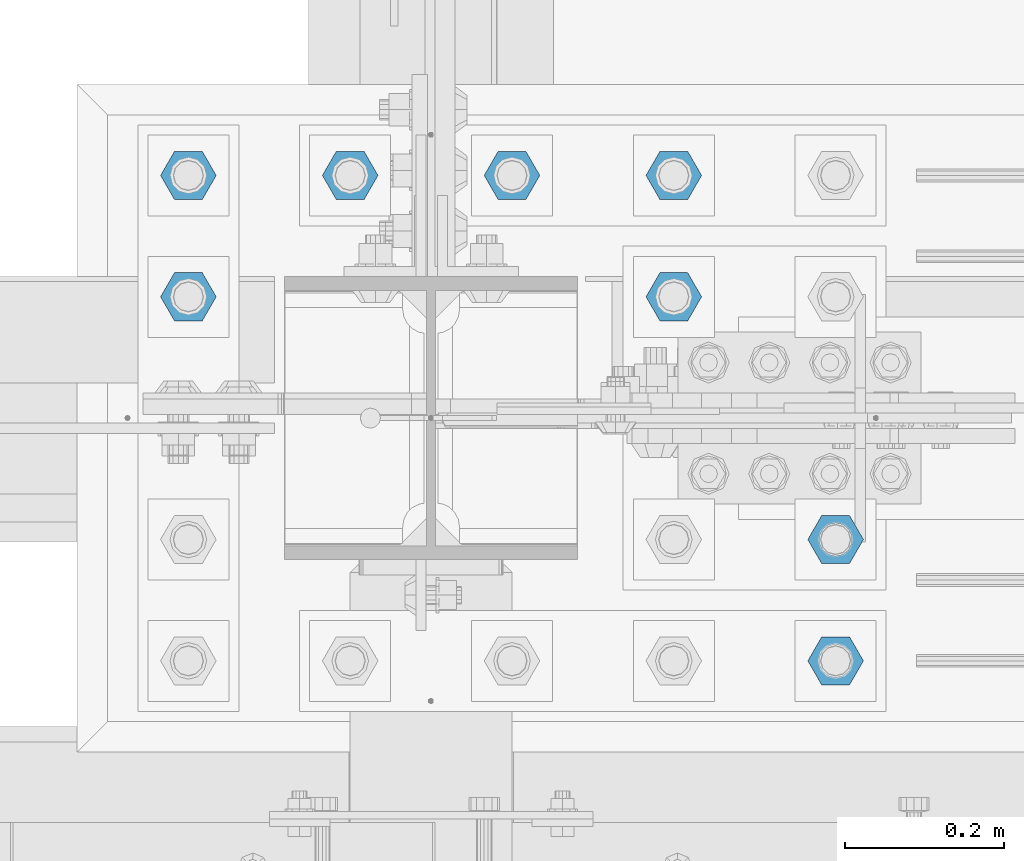
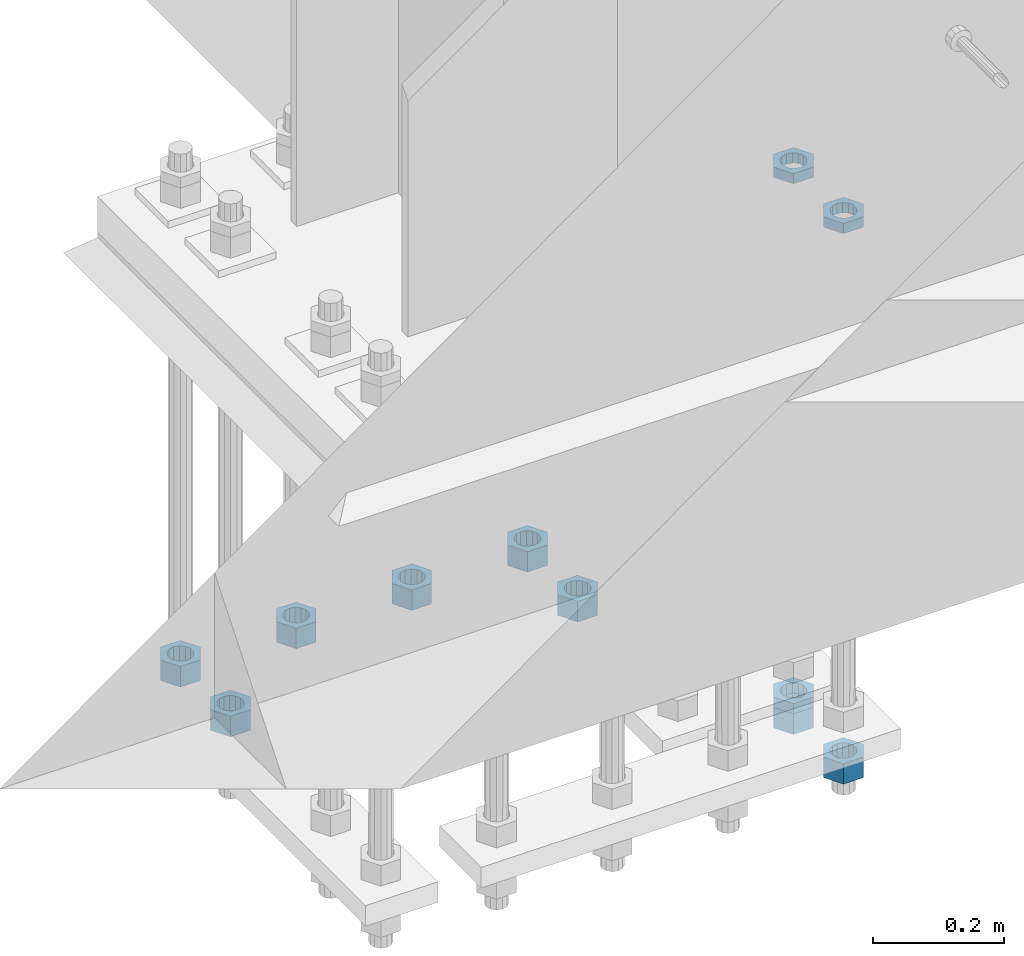
# One storey, part 2792 of 3843: 11 beams, 1 element without a shape of its own.
"""IFC2X3 building model written with IfcOpenShell, lengths in millimetres."""

from ifc_helpers import new_model, si_unit, frame, origin_with_axes, place, context, subcontext, project, spatial, faceted_brep, material, type_object, element, aggregate, save


model = new_model("IFC2X3")

# Units and contexts
model_context = context("Model", 3, precision=1e-05, world=origin_with_axes())
body_context = subcontext(model_context, "Body", "Model", "MODEL_VIEW")
ifc_project = project(units=[si_unit("LENGTHUNIT", "METRE", prefix="MILLI"), si_unit("AREAUNIT", "SQUARE_METRE"), si_unit("VOLUMEUNIT", "CUBIC_METRE"), si_unit("MASSUNIT", "GRAM", prefix="KILO"), si_unit("TIMEUNIT", "SECOND"), si_unit("PLANEANGLEUNIT", "RADIAN"), si_unit("SOLIDANGLEUNIT", "STERADIAN"), si_unit("THERMODYNAMICTEMPERATUREUNIT", "DEGREE_CELSIUS"), si_unit("LUMINOUSINTENSITYUNIT", "LUMEN")], contexts=[model_context])

# Site, building, storey
site_placement = place(None, origin_with_axes())
site = spatial("IfcSite", under=ifc_project, at=site_placement, CompositionType="ELEMENT")
building_placement = place(site_placement, origin_with_axes())
building = spatial("IfcBuilding", under=site, at=building_placement, Name="Undefined", CompositionType="ELEMENT")
storey_placement = place(building_placement, origin_with_axes())
storey = spatial("IfcBuildingStorey", under=building, at=storey_placement, Name="Undefined", CompositionType="ELEMENT", Elevation=0.0)

# Assembly, beams
assembly_placement = place(storey_placement, origin_with_axes())
assembly = element("IfcElementAssembly", 1, at=assembly_placement, inside=storey, Name="TEMPLATE", AssemblyPlace="NOTDEFINED", PredefinedType="RIGID_FRAME")
ifc_material = material(Name="STEEL/A572-50")
beam_type_1 = type_object("IfcBeamType", Name="1-1/2_HEAVY_HEX_NUT", PredefinedType="NOTDEFINED")
beam_1_placement = place(assembly_placement, frame((41960.8, 25920.7, 28841.7000015259), z_axis=(0.0, -1.0, 0.0), x_axis=(0.0, 0.0, -1.0)))
beam_1 = element("IfcBeam", 2, at=beam_1_placement, type_object=beam_type_1, material=ifc_material, Name="NUT", ObjectType="1-1/2_HEAVY_HEX_NUT", context=body_context, shape_type="Brep", body=[
    faceted_brep([(0.0, -34.9199981689453, 0.0), (0.0, -17.4599990844727, -30.25), (38.0999999999985, -17.4599990844727, -30.25), (38.0999999999985, -34.9199981689453, 0.0), (0.0, 17.4599990844727, -30.25), (38.0999999999985, 17.4599990844727, -30.25), (0.0, 34.9199981689453, 0.0), (38.0999999999985, 34.9199981689453, 0.0), (0.0, 17.4599990844727, 30.25), (38.0999999999985, 17.4599990844727, 30.25), (0.0, -17.4599990844727, 30.25), (38.0999999999985, -17.4599990844727, 30.25), (0.0, 0.0, 20.6399993896484), (0.0, 8.9553601105581, 18.5959968835959), (38.0999999999985, 8.9553601105581, 18.5959968835959), (38.0999999999985, 0.0, 20.6399993896484), (0.0, 16.1370013209525, 12.8688291298167), (38.0999999999985, 16.1370013209525, 12.8688291298167), (0.0, 20.1225115123816, 4.59283194104501), (38.0999999999985, 20.1225115123816, 4.59283194104501), (0.0, 20.1225115123816, -4.59283194104501), (38.0999999999985, 20.1225115123816, -4.59283194104501), (0.0, 16.1370013209525, -12.8688291298167), (38.0999999999985, 16.1370013209525, -12.8688291298167), (0.0, 8.9553601105581, -18.5959968835959), (38.0999999999985, 8.9553601105581, -18.5959968835959), (0.0, 0.0, -20.6399993896484), (38.0999999999985, 0.0, -20.6399993896484), (0.0, -8.9553601105581, -18.5959968835959), (38.0999999999985, -8.9553601105581, -18.5959968835959), (0.0, -16.1370013209525, -12.8688291298167), (38.0999999999985, -16.1370013209525, -12.8688291298167), (0.0, -20.1225115123816, -4.59283194104501), (38.0999999999985, -20.1225115123816, -4.59283194104501), (0.0, -20.1225115123816, 4.59283194104501), (38.0999999999985, -20.1225115123816, 4.59283194104501), (0.0, -16.1370013209525, 12.8688291298167), (38.0999999999985, -16.1370013209525, 12.8688291298167), (0.0, -8.9553601105581, 18.5959968835959), (38.0999999999985, -8.9553601105581, 18.5959968835959)], [[[0, 1, 2, 3]], [[1, 4, 5, 2]], [[4, 6, 7, 5]], [[6, 8, 9, 7]], [[8, 10, 11, 9]], [[10, 0, 3, 11]], [[12, 13, 14, 15]], [[13, 16, 17, 14]], [[16, 18, 19, 17]], [[18, 20, 21, 19]], [[20, 22, 23, 21]], [[22, 24, 25, 23]], [[24, 26, 27, 25]], [[26, 28, 29, 27]], [[28, 30, 31, 29]], [[30, 32, 33, 31]], [[32, 34, 35, 33]], [[34, 36, 37, 35]], [[36, 38, 39, 37]], [[38, 12, 15, 39]], [[5, 7, 9, 11, 3, 2], [17, 19, 21, 23, 25, 27, 29, 31, 33, 35, 37, 39, 15, 14]], [[10, 8, 6, 4, 1, 0], [38, 36, 34, 32, 30, 28, 26, 24, 22, 20, 18, 16, 13, 12]]]),
])
beam_2_placement = place(assembly_placement, frame((42164.0, 25920.7, 28841.7000015259), z_axis=(0.0, -1.0, 0.0), x_axis=(0.0, 0.0, -1.0)))
beam_2 = element("IfcBeam", 3, at=beam_2_placement, type_object=beam_type_1, material=ifc_material, Name="NUT", ObjectType="1-1/2_HEAVY_HEX_NUT", context=body_context, shape_type="Brep", body=[
    faceted_brep([(0.0, -34.9199981689453, 0.0), (0.0, -17.4599990844727, -30.25), (38.0999999999985, -17.4599990844727, -30.25), (38.0999999999985, -34.9199981689453, 0.0), (0.0, 17.4599990844727, -30.25), (38.0999999999985, 17.4599990844727, -30.25), (0.0, 34.9199981689453, 0.0), (38.0999999999985, 34.9199981689453, 0.0), (0.0, 17.4599990844727, 30.25), (38.0999999999985, 17.4599990844727, 30.25), (0.0, -17.4599990844727, 30.25), (38.0999999999985, -17.4599990844727, 30.25), (0.0, 0.0, 20.6399993896484), (0.0, 8.9553601105581, 18.5959968835959), (38.0999999999985, 8.9553601105581, 18.5959968835959), (38.0999999999985, 0.0, 20.6399993896484), (0.0, 16.1370013209525, 12.8688291298167), (38.0999999999985, 16.1370013209525, 12.8688291298167), (0.0, 20.1225115123816, 4.59283194104501), (38.0999999999985, 20.1225115123816, 4.59283194104501), (0.0, 20.1225115123816, -4.59283194104501), (38.0999999999985, 20.1225115123816, -4.59283194104501), (0.0, 16.1370013209525, -12.8688291298167), (38.0999999999985, 16.1370013209525, -12.8688291298167), (0.0, 8.9553601105581, -18.5959968835959), (38.0999999999985, 8.9553601105581, -18.5959968835959), (0.0, 0.0, -20.6399993896484), (38.0999999999985, 0.0, -20.6399993896484), (0.0, -8.9553601105581, -18.5959968835959), (38.0999999999985, -8.9553601105581, -18.5959968835959), (0.0, -16.1370013209525, -12.8688291298167), (38.0999999999985, -16.1370013209525, -12.8688291298167), (0.0, -20.1225115123816, -4.59283194104501), (38.0999999999985, -20.1225115123816, -4.59283194104501), (0.0, -20.1225115123816, 4.59283194104501), (38.0999999999985, -20.1225115123816, 4.59283194104501), (0.0, -16.1370013209525, 12.8688291298167), (38.0999999999985, -16.1370013209525, 12.8688291298167), (0.0, -8.9553601105581, 18.5959968835959), (38.0999999999985, -8.9553601105581, 18.5959968835959)], [[[0, 1, 2, 3]], [[1, 4, 5, 2]], [[4, 6, 7, 5]], [[6, 8, 9, 7]], [[8, 10, 11, 9]], [[10, 0, 3, 11]], [[12, 13, 14, 15]], [[13, 16, 17, 14]], [[16, 18, 19, 17]], [[18, 20, 21, 19]], [[20, 22, 23, 21]], [[22, 24, 25, 23]], [[24, 26, 27, 25]], [[26, 28, 29, 27]], [[28, 30, 31, 29]], [[30, 32, 33, 31]], [[32, 34, 35, 33]], [[34, 36, 37, 35]], [[36, 38, 39, 37]], [[38, 12, 15, 39]], [[5, 7, 9, 11, 3, 2], [17, 19, 21, 23, 25, 27, 29, 31, 33, 35, 37, 39, 15, 14]], [[10, 8, 6, 4, 1, 0], [38, 36, 34, 32, 30, 28, 26, 24, 22, 20, 18, 16, 13, 12]]]),
])
beam_3_placement = place(assembly_placement, frame((42367.2, 25920.7, 28841.7000015259), z_axis=(0.0, 1.0, 0.0), x_axis=(0.0, 0.0, -1.0)))
beam_3 = element("IfcBeam", 4, at=beam_3_placement, type_object=beam_type_1, material=ifc_material, Name="NUT", ObjectType="1-1/2_HEAVY_HEX_NUT", context=body_context, shape_type="Brep", body=[
    faceted_brep([(0.0, -34.9199981689453, 0.0), (0.0, -17.4599990844727, -30.25), (38.0999999999985, -17.4599990844727, -30.25), (38.0999999999985, -34.9199981689453, 0.0), (0.0, 17.4599990844727, -30.25), (38.0999999999985, 17.4599990844727, -30.25), (0.0, 34.9199981689453, 0.0), (38.0999999999985, 34.9199981689453, 0.0), (0.0, 17.4599990844727, 30.25), (38.0999999999985, 17.4599990844727, 30.25), (0.0, -17.4599990844727, 30.25), (38.0999999999985, -17.4599990844727, 30.25), (0.0, 0.0, 20.6399993896484), (0.0, 8.9553601105581, 18.5959968835959), (38.0999999999985, 8.9553601105581, 18.5959968835959), (38.0999999999985, 0.0, 20.6399993896484), (0.0, 16.1370013209525, 12.8688291298167), (38.0999999999985, 16.1370013209525, 12.8688291298167), (0.0, 20.1225115123816, 4.59283194104501), (38.0999999999985, 20.1225115123816, 4.59283194104501), (0.0, 20.1225115123816, -4.59283194104501), (38.0999999999985, 20.1225115123816, -4.59283194104501), (0.0, 16.1370013209525, -12.8688291298167), (38.0999999999985, 16.1370013209525, -12.8688291298167), (0.0, 8.9553601105581, -18.5959968835959), (38.0999999999985, 8.9553601105581, -18.5959968835959), (0.0, 0.0, -20.6399993896484), (38.0999999999985, 0.0, -20.6399993896484), (0.0, -8.9553601105581, -18.5959968835959), (38.0999999999985, -8.9553601105581, -18.5959968835959), (0.0, -16.1370013209525, -12.8688291298167), (38.0999999999985, -16.1370013209525, -12.8688291298167), (0.0, -20.1225115123816, -4.59283194104501), (38.0999999999985, -20.1225115123816, -4.59283194104501), (0.0, -20.1225115123816, 4.59283194104501), (38.0999999999985, -20.1225115123816, 4.59283194104501), (0.0, -16.1370013209525, 12.8688291298167), (38.0999999999985, -16.1370013209525, 12.8688291298167), (0.0, -8.9553601105581, 18.5959968835959), (38.0999999999985, -8.9553601105581, 18.5959968835959)], [[[0, 1, 2, 3]], [[1, 4, 5, 2]], [[4, 6, 7, 5]], [[6, 8, 9, 7]], [[8, 10, 11, 9]], [[10, 0, 3, 11]], [[12, 13, 14, 15]], [[13, 16, 17, 14]], [[16, 18, 19, 17]], [[18, 20, 21, 19]], [[20, 22, 23, 21]], [[22, 24, 25, 23]], [[24, 26, 27, 25]], [[26, 28, 29, 27]], [[28, 30, 31, 29]], [[30, 32, 33, 31]], [[32, 34, 35, 33]], [[34, 36, 37, 35]], [[36, 38, 39, 37]], [[38, 12, 15, 39]], [[5, 7, 9, 11, 3, 2], [17, 19, 21, 23, 25, 27, 29, 31, 33, 35, 37, 39, 15, 14]], [[10, 8, 6, 4, 1, 0], [38, 36, 34, 32, 30, 28, 26, 24, 22, 20, 18, 16, 13, 12]]]),
])
beam_4_placement = place(assembly_placement, frame((42367.2, 25768.3, 28841.7000015259), z_axis=(0.0, 1.0, 0.0), x_axis=(0.0, 0.0, -1.0)))
beam_4 = element("IfcBeam", 5, at=beam_4_placement, type_object=beam_type_1, material=ifc_material, Name="NUT", ObjectType="1-1/2_HEAVY_HEX_NUT", context=body_context, shape_type="Brep", body=[
    faceted_brep([(0.0, -34.9199981689453, 0.0), (0.0, -17.4599990844727, -30.25), (38.0999999999985, -17.4599990844727, -30.25), (38.0999999999985, -34.9199981689453, 0.0), (0.0, 17.4599990844727, -30.25), (38.0999999999985, 17.4599990844727, -30.25), (0.0, 34.9199981689453, 0.0), (38.0999999999985, 34.9199981689453, 0.0), (0.0, 17.4599990844727, 30.25), (38.0999999999985, 17.4599990844727, 30.25), (0.0, -17.4599990844727, 30.25), (38.0999999999985, -17.4599990844727, 30.25), (0.0, 0.0, 20.6399993896484), (0.0, 8.9553601105581, 18.5959968835959), (38.0999999999985, 8.9553601105581, 18.5959968835959), (38.0999999999985, 0.0, 20.6399993896484), (0.0, 16.1370013209525, 12.8688291298167), (38.0999999999985, 16.1370013209525, 12.8688291298167), (0.0, 20.1225115123816, 4.59283194104501), (38.0999999999985, 20.1225115123816, 4.59283194104501), (0.0, 20.1225115123816, -4.59283194104501), (38.0999999999985, 20.1225115123816, -4.59283194104501), (0.0, 16.1370013209525, -12.8688291298167), (38.0999999999985, 16.1370013209525, -12.8688291298167), (0.0, 8.9553601105581, -18.5959968835959), (38.0999999999985, 8.9553601105581, -18.5959968835959), (0.0, 0.0, -20.6399993896484), (38.0999999999985, 0.0, -20.6399993896484), (0.0, -8.9553601105581, -18.5959968835959), (38.0999999999985, -8.9553601105581, -18.5959968835959), (0.0, -16.1370013209525, -12.8688291298167), (38.0999999999985, -16.1370013209525, -12.8688291298167), (0.0, -20.1225115123816, -4.59283194104501), (38.0999999999985, -20.1225115123816, -4.59283194104501), (0.0, -20.1225115123816, 4.59283194104501), (38.0999999999985, -20.1225115123816, 4.59283194104501), (0.0, -16.1370013209525, 12.8688291298167), (38.0999999999985, -16.1370013209525, 12.8688291298167), (0.0, -8.9553601105581, 18.5959968835959), (38.0999999999985, -8.9553601105581, 18.5959968835959)], [[[0, 1, 2, 3]], [[1, 4, 5, 2]], [[4, 6, 7, 5]], [[6, 8, 9, 7]], [[8, 10, 11, 9]], [[10, 0, 3, 11]], [[12, 13, 14, 15]], [[13, 16, 17, 14]], [[16, 18, 19, 17]], [[18, 20, 21, 19]], [[20, 22, 23, 21]], [[22, 24, 25, 23]], [[24, 26, 27, 25]], [[26, 28, 29, 27]], [[28, 30, 31, 29]], [[30, 32, 33, 31]], [[32, 34, 35, 33]], [[34, 36, 37, 35]], [[36, 38, 39, 37]], [[38, 12, 15, 39]], [[5, 7, 9, 11, 3, 2], [17, 19, 21, 23, 25, 27, 29, 31, 33, 35, 37, 39, 15, 14]], [[10, 8, 6, 4, 1, 0], [38, 36, 34, 32, 30, 28, 26, 24, 22, 20, 18, 16, 13, 12]]]),
])
beam_5_placement = place(assembly_placement, frame((41757.6, 25920.7, 28841.7000015259), z_axis=(0.0, -1.0, 0.0), x_axis=(0.0, 0.0, -1.0)))
beam_5 = element("IfcBeam", 6, at=beam_5_placement, type_object=beam_type_1, material=ifc_material, Name="NUT", ObjectType="1-1/2_HEAVY_HEX_NUT", context=body_context, shape_type="Brep", body=[
    faceted_brep([(0.0, -34.9199981689453, 0.0), (0.0, -17.4599990844727, -30.25), (38.0999999999985, -17.4599990844727, -30.25), (38.0999999999985, -34.9199981689453, 0.0), (0.0, 17.4599990844727, -30.25), (38.0999999999985, 17.4599990844727, -30.25), (0.0, 34.9199981689453, 0.0), (38.0999999999985, 34.9199981689453, 0.0), (0.0, 17.4599990844727, 30.25), (38.0999999999985, 17.4599990844727, 30.25), (0.0, -17.4599990844727, 30.25), (38.0999999999985, -17.4599990844727, 30.25), (0.0, 0.0, 20.6399993896484), (0.0, 8.9553601105581, 18.5959968835959), (38.0999999999985, 8.9553601105581, 18.5959968835959), (38.0999999999985, 0.0, 20.6399993896484), (0.0, 16.1370013209525, 12.8688291298167), (38.0999999999985, 16.1370013209525, 12.8688291298167), (0.0, 20.1225115123816, 4.59283194104501), (38.0999999999985, 20.1225115123816, 4.59283194104501), (0.0, 20.1225115123816, -4.59283194104501), (38.0999999999985, 20.1225115123816, -4.59283194104501), (0.0, 16.1370013209525, -12.8688291298167), (38.0999999999985, 16.1370013209525, -12.8688291298167), (0.0, 8.9553601105581, -18.5959968835959), (38.0999999999985, 8.9553601105581, -18.5959968835959), (0.0, 0.0, -20.6399993896484), (38.0999999999985, 0.0, -20.6399993896484), (0.0, -8.9553601105581, -18.5959968835959), (38.0999999999985, -8.9553601105581, -18.5959968835959), (0.0, -16.1370013209525, -12.8688291298167), (38.0999999999985, -16.1370013209525, -12.8688291298167), (0.0, -20.1225115123816, -4.59283194104501), (38.0999999999985, -20.1225115123816, -4.59283194104501), (0.0, -20.1225115123816, 4.59283194104501), (38.0999999999985, -20.1225115123816, 4.59283194104501), (0.0, -16.1370013209525, 12.8688291298167), (38.0999999999985, -16.1370013209525, 12.8688291298167), (0.0, -8.9553601105581, 18.5959968835959), (38.0999999999985, -8.9553601105581, 18.5959968835959)], [[[0, 1, 2, 3]], [[1, 4, 5, 2]], [[4, 6, 7, 5]], [[6, 8, 9, 7]], [[8, 10, 11, 9]], [[10, 0, 3, 11]], [[12, 13, 14, 15]], [[13, 16, 17, 14]], [[16, 18, 19, 17]], [[18, 20, 21, 19]], [[20, 22, 23, 21]], [[22, 24, 25, 23]], [[24, 26, 27, 25]], [[26, 28, 29, 27]], [[28, 30, 31, 29]], [[30, 32, 33, 31]], [[32, 34, 35, 33]], [[34, 36, 37, 35]], [[36, 38, 39, 37]], [[38, 12, 15, 39]], [[5, 7, 9, 11, 3, 2], [17, 19, 21, 23, 25, 27, 29, 31, 33, 35, 37, 39, 15, 14]], [[10, 8, 6, 4, 1, 0], [38, 36, 34, 32, 30, 28, 26, 24, 22, 20, 18, 16, 13, 12]]]),
])
beam_6_placement = place(assembly_placement, frame((41757.6, 25768.3, 28841.7000015259), z_axis=(0.0, -1.0, 0.0), x_axis=(0.0, 0.0, -1.0)))
beam_6 = element("IfcBeam", 7, at=beam_6_placement, type_object=beam_type_1, material=ifc_material, Name="NUT", ObjectType="1-1/2_HEAVY_HEX_NUT", context=body_context, shape_type="Brep", body=[
    faceted_brep([(0.0, -34.9199981689453, 0.0), (0.0, -17.4599990844727, -30.25), (38.0999999999985, -17.4599990844727, -30.25), (38.0999999999985, -34.9199981689453, 0.0), (0.0, 17.4599990844727, -30.25), (38.0999999999985, 17.4599990844727, -30.25), (0.0, 34.9199981689453, 0.0), (38.0999999999985, 34.9199981689453, 0.0), (0.0, 17.4599990844727, 30.25), (38.0999999999985, 17.4599990844727, 30.25), (0.0, -17.4599990844727, 30.25), (38.0999999999985, -17.4599990844727, 30.25), (0.0, 0.0, 20.6399993896484), (0.0, 8.9553601105581, 18.5959968835959), (38.0999999999985, 8.9553601105581, 18.5959968835959), (38.0999999999985, 0.0, 20.6399993896484), (0.0, 16.1370013209525, 12.8688291298167), (38.0999999999985, 16.1370013209525, 12.8688291298167), (0.0, 20.1225115123816, 4.59283194104501), (38.0999999999985, 20.1225115123816, 4.59283194104501), (0.0, 20.1225115123816, -4.59283194104501), (38.0999999999985, 20.1225115123816, -4.59283194104501), (0.0, 16.1370013209525, -12.8688291298167), (38.0999999999985, 16.1370013209525, -12.8688291298167), (0.0, 8.9553601105581, -18.5959968835959), (38.0999999999985, 8.9553601105581, -18.5959968835959), (0.0, 0.0, -20.6399993896484), (38.0999999999985, 0.0, -20.6399993896484), (0.0, -8.9553601105581, -18.5959968835959), (38.0999999999985, -8.9553601105581, -18.5959968835959), (0.0, -16.1370013209525, -12.8688291298167), (38.0999999999985, -16.1370013209525, -12.8688291298167), (0.0, -20.1225115123816, -4.59283194104501), (38.0999999999985, -20.1225115123816, -4.59283194104501), (0.0, -20.1225115123816, 4.59283194104501), (38.0999999999985, -20.1225115123816, 4.59283194104501), (0.0, -16.1370013209525, 12.8688291298167), (38.0999999999985, -16.1370013209525, 12.8688291298167), (0.0, -8.9553601105581, 18.5959968835959), (38.0999999999985, -8.9553601105581, 18.5959968835959)], [[[0, 1, 2, 3]], [[1, 4, 5, 2]], [[4, 6, 7, 5]], [[6, 8, 9, 7]], [[8, 10, 11, 9]], [[10, 0, 3, 11]], [[12, 13, 14, 15]], [[13, 16, 17, 14]], [[16, 18, 19, 17]], [[18, 20, 21, 19]], [[20, 22, 23, 21]], [[22, 24, 25, 23]], [[24, 26, 27, 25]], [[26, 28, 29, 27]], [[28, 30, 31, 29]], [[30, 32, 33, 31]], [[32, 34, 35, 33]], [[34, 36, 37, 35]], [[36, 38, 39, 37]], [[38, 12, 15, 39]], [[5, 7, 9, 11, 3, 2], [17, 19, 21, 23, 25, 27, 29, 31, 33, 35, 37, 39, 15, 14]], [[10, 8, 6, 4, 1, 0], [38, 36, 34, 32, 30, 28, 26, 24, 22, 20, 18, 16, 13, 12]]]),
])
beam_7_placement = place(assembly_placement, frame((42570.4, 25311.1, 28746.4500015259), z_axis=(0.0, 1.0, 0.0), x_axis=(0.0, 0.0, -1.0)))
beam_7 = element("IfcBeam", 8, at=beam_7_placement, type_object=beam_type_1, material=ifc_material, Name="NUT", ObjectType="1-1/2_HEAVY_HEX_NUT", context=body_context, shape_type="Brep", body=[
    faceted_brep([(0.0, -34.9199981689453, 0.0), (0.0, -17.4599990844727, -30.25), (38.0999999999985, -17.4599990844727, -30.25), (38.0999999999985, -34.9199981689453, 0.0), (0.0, 17.4599990844727, -30.25), (38.0999999999985, 17.4599990844727, -30.25), (0.0, 34.9199981689453, 0.0), (38.0999999999985, 34.9199981689453, 0.0), (0.0, 17.4599990844727, 30.25), (38.0999999999985, 17.4599990844727, 30.25), (0.0, -17.4599990844727, 30.25), (38.0999999999985, -17.4599990844727, 30.25), (0.0, 0.0, 20.6399993896484), (0.0, 8.9553601105581, 18.5959968835959), (38.0999999999985, 8.9553601105581, 18.5959968835959), (38.0999999999985, 0.0, 20.6399993896484), (0.0, 16.1370013209525, 12.8688291298167), (38.0999999999985, 16.1370013209525, 12.8688291298167), (0.0, 20.1225115123816, 4.59283194104501), (38.0999999999985, 20.1225115123816, 4.59283194104501), (0.0, 20.1225115123816, -4.59283194104501), (38.0999999999985, 20.1225115123816, -4.59283194104501), (0.0, 16.1370013209525, -12.8688291298167), (38.0999999999985, 16.1370013209525, -12.8688291298167), (0.0, 8.9553601105581, -18.5959968835959), (38.0999999999985, 8.9553601105581, -18.5959968835959), (0.0, 0.0, -20.6399993896484), (38.0999999999985, 0.0, -20.6399993896484), (0.0, -8.9553601105581, -18.5959968835959), (38.0999999999985, -8.9553601105581, -18.5959968835959), (0.0, -16.1370013209525, -12.8688291298167), (38.0999999999985, -16.1370013209525, -12.8688291298167), (0.0, -20.1225115123816, -4.59283194104501), (38.0999999999985, -20.1225115123816, -4.59283194104501), (0.0, -20.1225115123816, 4.59283194104501), (38.0999999999985, -20.1225115123816, 4.59283194104501), (0.0, -16.1370013209525, 12.8688291298167), (38.0999999999985, -16.1370013209525, 12.8688291298167), (0.0, -8.9553601105581, 18.5959968835959), (38.0999999999985, -8.9553601105581, 18.5959968835959)], [[[0, 1, 2, 3]], [[1, 4, 5, 2]], [[4, 6, 7, 5]], [[6, 8, 9, 7]], [[8, 10, 11, 9]], [[10, 0, 3, 11]], [[12, 13, 14, 15]], [[13, 16, 17, 14]], [[16, 18, 19, 17]], [[18, 20, 21, 19]], [[20, 22, 23, 21]], [[22, 24, 25, 23]], [[24, 26, 27, 25]], [[26, 28, 29, 27]], [[28, 30, 31, 29]], [[30, 32, 33, 31]], [[32, 34, 35, 33]], [[34, 36, 37, 35]], [[36, 38, 39, 37]], [[38, 12, 15, 39]], [[5, 7, 9, 11, 3, 2], [17, 19, 21, 23, 25, 27, 29, 31, 33, 35, 37, 39, 15, 14]], [[10, 8, 6, 4, 1, 0], [38, 36, 34, 32, 30, 28, 26, 24, 22, 20, 18, 16, 13, 12]]]),
])
beam_8_placement = place(assembly_placement, frame((42570.4, 25463.5, 28746.4500015259), z_axis=(0.0, 1.0, 0.0), x_axis=(0.0, 0.0, -1.0)))
beam_8 = element("IfcBeam", 9, at=beam_8_placement, type_object=beam_type_1, material=ifc_material, Name="NUT", ObjectType="1-1/2_HEAVY_HEX_NUT", context=body_context, shape_type="Brep", body=[
    faceted_brep([(0.0, -34.9199981689453, 0.0), (0.0, -17.4599990844727, -30.25), (38.0999999999985, -17.4599990844727, -30.25), (38.0999999999985, -34.9199981689453, 0.0), (0.0, 17.4599990844727, -30.25), (38.0999999999985, 17.4599990844727, -30.25), (0.0, 34.9199981689453, 0.0), (38.0999999999985, 34.9199981689453, 0.0), (0.0, 17.4599990844727, 30.25), (38.0999999999985, 17.4599990844727, 30.25), (0.0, -17.4599990844727, 30.25), (38.0999999999985, -17.4599990844727, 30.25), (0.0, 0.0, 20.6399993896484), (0.0, 8.9553601105581, 18.5959968835959), (38.0999999999985, 8.9553601105581, 18.5959968835959), (38.0999999999985, 0.0, 20.6399993896484), (0.0, 16.1370013209525, 12.8688291298167), (38.0999999999985, 16.1370013209525, 12.8688291298167), (0.0, 20.1225115123816, 4.59283194104501), (38.0999999999985, 20.1225115123816, 4.59283194104501), (0.0, 20.1225115123816, -4.59283194104501), (38.0999999999985, 20.1225115123816, -4.59283194104501), (0.0, 16.1370013209525, -12.8688291298167), (38.0999999999985, 16.1370013209525, -12.8688291298167), (0.0, 8.9553601105581, -18.5959968835959), (38.0999999999985, 8.9553601105581, -18.5959968835959), (0.0, 0.0, -20.6399993896484), (38.0999999999985, 0.0, -20.6399993896484), (0.0, -8.9553601105581, -18.5959968835959), (38.0999999999985, -8.9553601105581, -18.5959968835959), (0.0, -16.1370013209525, -12.8688291298167), (38.0999999999985, -16.1370013209525, -12.8688291298167), (0.0, -20.1225115123816, -4.59283194104501), (38.0999999999985, -20.1225115123816, -4.59283194104501), (0.0, -20.1225115123816, 4.59283194104501), (38.0999999999985, -20.1225115123816, 4.59283194104501), (0.0, -16.1370013209525, 12.8688291298167), (38.0999999999985, -16.1370013209525, 12.8688291298167), (0.0, -8.9553601105581, 18.5959968835959), (38.0999999999985, -8.9553601105581, 18.5959968835959)], [[[0, 1, 2, 3]], [[1, 4, 5, 2]], [[4, 6, 7, 5]], [[6, 8, 9, 7]], [[8, 10, 11, 9]], [[10, 0, 3, 11]], [[12, 13, 14, 15]], [[13, 16, 17, 14]], [[16, 18, 19, 17]], [[18, 20, 21, 19]], [[20, 22, 23, 21]], [[22, 24, 25, 23]], [[24, 26, 27, 25]], [[26, 28, 29, 27]], [[28, 30, 31, 29]], [[30, 32, 33, 31]], [[32, 34, 35, 33]], [[34, 36, 37, 35]], [[36, 38, 39, 37]], [[38, 12, 15, 39]], [[5, 7, 9, 11, 3, 2], [17, 19, 21, 23, 25, 27, 29, 31, 33, 35, 37, 39, 15, 14]], [[10, 8, 6, 4, 1, 0], [38, 36, 34, 32, 30, 28, 26, 24, 22, 20, 18, 16, 13, 12]]]),
])
beam_type_2 = type_object("IfcBeamType", Name="1-1/2_HALF_NUT", PredefinedType="NOTDEFINED")
beam_9_placement = place(assembly_placement, frame((42570.4, 25463.5, 28765.5000015259), z_axis=(0.0, 1.0, 0.0), x_axis=(0.0, 0.0, -1.0)))
beam_9 = element("IfcBeam", 10, at=beam_9_placement, type_object=beam_type_2, material=ifc_material, Name="NUT", ObjectType="1-1/2_HALF_NUT", context=body_context, shape_type="Brep", body=[
    faceted_brep([(0.0, -34.9199981689453, 0.0), (0.0, -17.4599990844727, -30.25), (19.0500000000029, -17.4599990844727, -30.25), (19.0500000000029, -34.9199981689453, 0.0), (0.0, 17.4599990844727, -30.25), (19.0500000000029, 17.4599990844727, -30.25), (0.0, 34.9199981689453, 0.0), (19.0500000000029, 34.9199981689453, 0.0), (0.0, 17.4599990844727, 30.25), (19.0500000000029, 17.4599990844727, 30.25), (0.0, -17.4599990844727, 30.25), (19.0500000000029, -17.4599990844727, 30.25), (0.0, 0.0, 20.6399993896484), (0.0, 8.9553601105581, 18.5959968835959), (19.0500000000029, 8.95536011056538, 18.5959968835959), (19.0500000000029, 0.0, 20.6399993896484), (0.0, 16.1370013209525, 12.8688291298167), (19.0500000000029, 16.1370013209489, 12.8688291298167), (0.0, 20.1225115123816, 4.59283194104501), (19.0500000000029, 20.1225115123852, 4.59283194104501), (0.0, 20.1225115123816, -4.59283194104501), (19.0500000000029, 20.1225115123852, -4.59283194104501), (0.0, 16.1370013209525, -12.8688291298167), (19.0500000000029, 16.1370013209489, -12.8688291298167), (0.0, 8.9553601105581, -18.5959968835959), (19.0500000000029, 8.95536011056538, -18.5959968835959), (0.0, 0.0, -20.6399993896484), (19.0500000000029, 0.0, -20.6399993896484), (0.0, -8.9553601105581, -18.5959968835959), (19.0500000000029, -8.95536011056538, -18.5959968835959), (0.0, -16.1370013209525, -12.8688291298167), (19.0500000000029, -16.1370013209489, -12.8688291298167), (0.0, -20.1225115123816, -4.59283194104501), (19.0500000000029, -20.1225115123852, -4.59283194104501), (0.0, -20.1225115123816, 4.59283194104501), (19.0500000000029, -20.1225115123852, 4.59283194104501), (0.0, -16.1370013209525, 12.8688291298167), (19.0500000000029, -16.1370013209489, 12.8688291298167), (0.0, -8.9553601105581, 18.5959968835959), (19.0500000000029, -8.95536011056538, 18.5959968835959)], [[[0, 1, 2, 3]], [[1, 4, 5, 2]], [[4, 6, 7, 5]], [[6, 8, 9, 7]], [[8, 10, 11, 9]], [[10, 0, 3, 11]], [[12, 13, 14, 15]], [[13, 16, 17, 14]], [[16, 18, 19, 17]], [[18, 20, 21, 19]], [[20, 22, 23, 21]], [[22, 24, 25, 23]], [[24, 26, 27, 25]], [[26, 28, 29, 27]], [[28, 30, 31, 29]], [[30, 32, 33, 31]], [[32, 34, 35, 33]], [[34, 36, 37, 35]], [[36, 38, 39, 37]], [[38, 12, 15, 39]], [[5, 7, 9, 11, 3, 2], [17, 19, 21, 23, 25, 27, 29, 31, 33, 35, 37, 39, 15, 14]], [[10, 8, 6, 4, 1, 0], [38, 36, 34, 32, 30, 28, 26, 24, 22, 20, 18, 16, 13, 12]]]),
])
beam_10_placement = place(assembly_placement, frame((42570.4, 25311.1, 29749.75), z_axis=(0.0, 1.0, 0.0), x_axis=(0.0, 0.0, -1.0)))
beam_10 = element("IfcBeam", 11, at=beam_10_placement, type_object=beam_type_2, material=ifc_material, Name="NUT", ObjectType="1-1/2_HALF_NUT", context=body_context, shape_type="Brep", body=[
    faceted_brep([(0.0, -34.9199981689453, 0.0), (0.0, -17.4599990844727, -30.25), (19.0500000000029, -17.4599990844727, -30.25), (19.0500000000029, -34.9199981689453, 0.0), (0.0, 17.4599990844727, -30.25), (19.0500000000029, 17.4599990844727, -30.25), (0.0, 34.9199981689453, 0.0), (19.0500000000029, 34.9199981689453, 0.0), (0.0, 17.4599990844727, 30.25), (19.0500000000029, 17.4599990844727, 30.25), (0.0, -17.4599990844727, 30.25), (19.0500000000029, -17.4599990844727, 30.25), (0.0, 0.0, 20.6399993896484), (0.0, 8.9553601105581, 18.5959968835959), (19.0500000000029, 8.95536011056538, 18.5959968835959), (19.0500000000029, 0.0, 20.6399993896484), (0.0, 16.1370013209525, 12.8688291298167), (19.0500000000029, 16.1370013209489, 12.8688291298167), (0.0, 20.1225115123816, 4.59283194104501), (19.0500000000029, 20.1225115123852, 4.59283194104501), (0.0, 20.1225115123816, -4.59283194104501), (19.0500000000029, 20.1225115123852, -4.59283194104501), (0.0, 16.1370013209525, -12.8688291298167), (19.0500000000029, 16.1370013209489, -12.8688291298167), (0.0, 8.9553601105581, -18.5959968835959), (19.0500000000029, 8.95536011056538, -18.5959968835959), (0.0, 0.0, -20.6399993896484), (19.0500000000029, 0.0, -20.6399993896484), (0.0, -8.9553601105581, -18.5959968835959), (19.0500000000029, -8.95536011056538, -18.5959968835959), (0.0, -16.1370013209525, -12.8688291298167), (19.0500000000029, -16.1370013209489, -12.8688291298167), (0.0, -20.1225115123816, -4.59283194104501), (19.0500000000029, -20.1225115123852, -4.59283194104501), (0.0, -20.1225115123816, 4.59283194104501), (19.0500000000029, -20.1225115123852, 4.59283194104501), (0.0, -16.1370013209525, 12.8688291298167), (19.0500000000029, -16.1370013209489, 12.8688291298167), (0.0, -8.9553601105581, 18.5959968835959), (19.0500000000029, -8.95536011056538, 18.5959968835959)], [[[0, 1, 2, 3]], [[1, 4, 5, 2]], [[4, 6, 7, 5]], [[6, 8, 9, 7]], [[8, 10, 11, 9]], [[10, 0, 3, 11]], [[12, 13, 14, 15]], [[13, 16, 17, 14]], [[16, 18, 19, 17]], [[18, 20, 21, 19]], [[20, 22, 23, 21]], [[22, 24, 25, 23]], [[24, 26, 27, 25]], [[26, 28, 29, 27]], [[28, 30, 31, 29]], [[30, 32, 33, 31]], [[32, 34, 35, 33]], [[34, 36, 37, 35]], [[36, 38, 39, 37]], [[38, 12, 15, 39]], [[5, 7, 9, 11, 3, 2], [17, 19, 21, 23, 25, 27, 29, 31, 33, 35, 37, 39, 15, 14]], [[10, 8, 6, 4, 1, 0], [38, 36, 34, 32, 30, 28, 26, 24, 22, 20, 18, 16, 13, 12]]]),
])
beam_11_placement = place(assembly_placement, frame((42570.4, 25463.5, 29749.75), z_axis=(0.0, 1.0, 0.0), x_axis=(0.0, 0.0, -1.0)))
beam_11 = element("IfcBeam", 12, at=beam_11_placement, type_object=beam_type_2, material=ifc_material, Name="NUT", ObjectType="1-1/2_HALF_NUT", context=body_context, shape_type="Brep", body=[
    faceted_brep([(0.0, -34.9199981689453, 0.0), (0.0, -17.4599990844727, -30.25), (19.0500000000029, -17.4599990844727, -30.25), (19.0500000000029, -34.9199981689453, 0.0), (0.0, 17.4599990844727, -30.25), (19.0500000000029, 17.4599990844727, -30.25), (0.0, 34.9199981689453, 0.0), (19.0500000000029, 34.9199981689453, 0.0), (0.0, 17.4599990844727, 30.25), (19.0500000000029, 17.4599990844727, 30.25), (0.0, -17.4599990844727, 30.25), (19.0500000000029, -17.4599990844727, 30.25), (0.0, 0.0, 20.6399993896484), (0.0, 8.9553601105581, 18.5959968835959), (19.0500000000029, 8.95536011056538, 18.5959968835959), (19.0500000000029, 0.0, 20.6399993896484), (0.0, 16.1370013209525, 12.8688291298167), (19.0500000000029, 16.1370013209489, 12.8688291298167), (0.0, 20.1225115123816, 4.59283194104501), (19.0500000000029, 20.1225115123852, 4.59283194104501), (0.0, 20.1225115123816, -4.59283194104501), (19.0500000000029, 20.1225115123852, -4.59283194104501), (0.0, 16.1370013209525, -12.8688291298167), (19.0500000000029, 16.1370013209489, -12.8688291298167), (0.0, 8.9553601105581, -18.5959968835959), (19.0500000000029, 8.95536011056538, -18.5959968835959), (0.0, 0.0, -20.6399993896484), (19.0500000000029, 0.0, -20.6399993896484), (0.0, -8.9553601105581, -18.5959968835959), (19.0500000000029, -8.95536011056538, -18.5959968835959), (0.0, -16.1370013209525, -12.8688291298167), (19.0500000000029, -16.1370013209489, -12.8688291298167), (0.0, -20.1225115123816, -4.59283194104501), (19.0500000000029, -20.1225115123852, -4.59283194104501), (0.0, -20.1225115123816, 4.59283194104501), (19.0500000000029, -20.1225115123852, 4.59283194104501), (0.0, -16.1370013209525, 12.8688291298167), (19.0500000000029, -16.1370013209489, 12.8688291298167), (0.0, -8.9553601105581, 18.5959968835959), (19.0500000000029, -8.95536011056538, 18.5959968835959)], [[[0, 1, 2, 3]], [[1, 4, 5, 2]], [[4, 6, 7, 5]], [[6, 8, 9, 7]], [[8, 10, 11, 9]], [[10, 0, 3, 11]], [[12, 13, 14, 15]], [[13, 16, 17, 14]], [[16, 18, 19, 17]], [[18, 20, 21, 19]], [[20, 22, 23, 21]], [[22, 24, 25, 23]], [[24, 26, 27, 25]], [[26, 28, 29, 27]], [[28, 30, 31, 29]], [[30, 32, 33, 31]], [[32, 34, 35, 33]], [[34, 36, 37, 35]], [[36, 38, 39, 37]], [[38, 12, 15, 39]], [[5, 7, 9, 11, 3, 2], [17, 19, 21, 23, 25, 27, 29, 31, 33, 35, 37, 39, 15, 14]], [[10, 8, 6, 4, 1, 0], [38, 36, 34, 32, 30, 28, 26, 24, 22, 20, 18, 16, 13, 12]]]),
])
aggregate(assembly, [beam_1, beam_2, beam_3, beam_4, beam_5, beam_6, beam_9, beam_7, beam_8, beam_10, beam_11])

save(model, "model.ifc")
